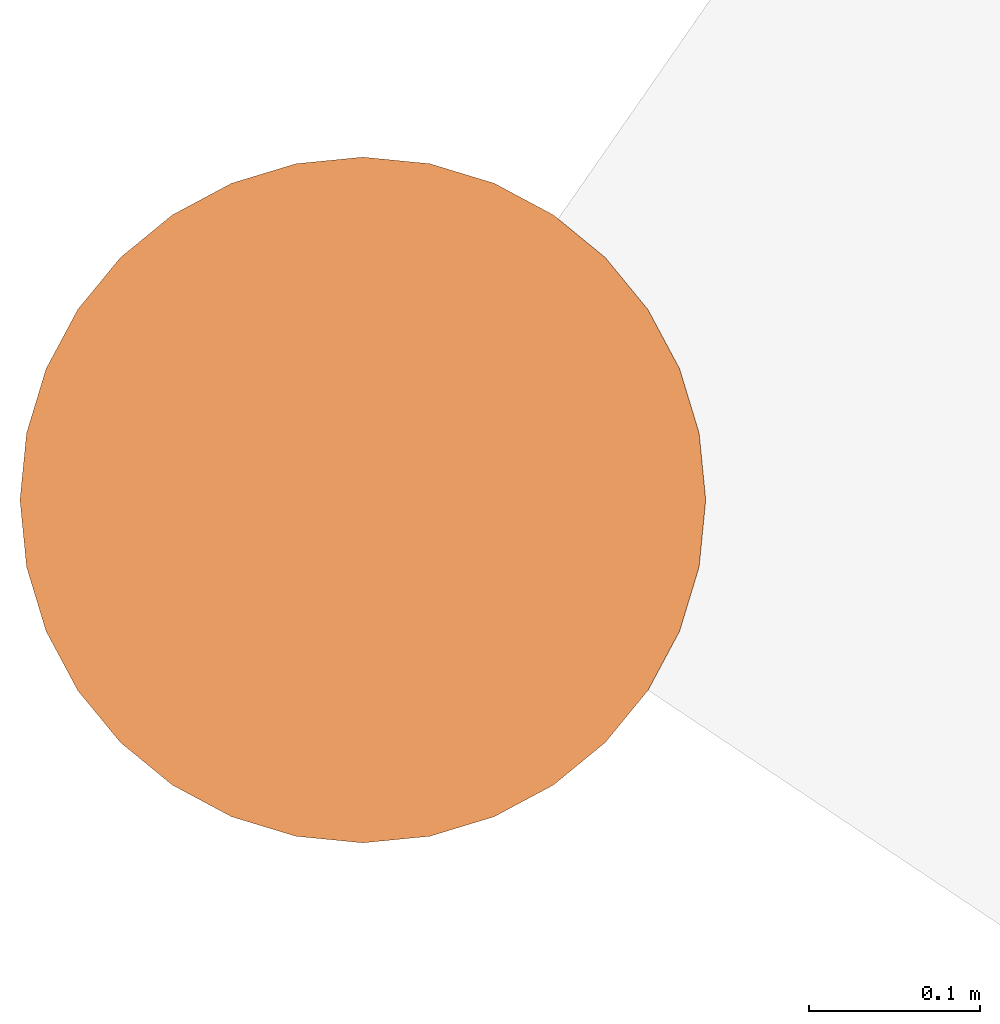
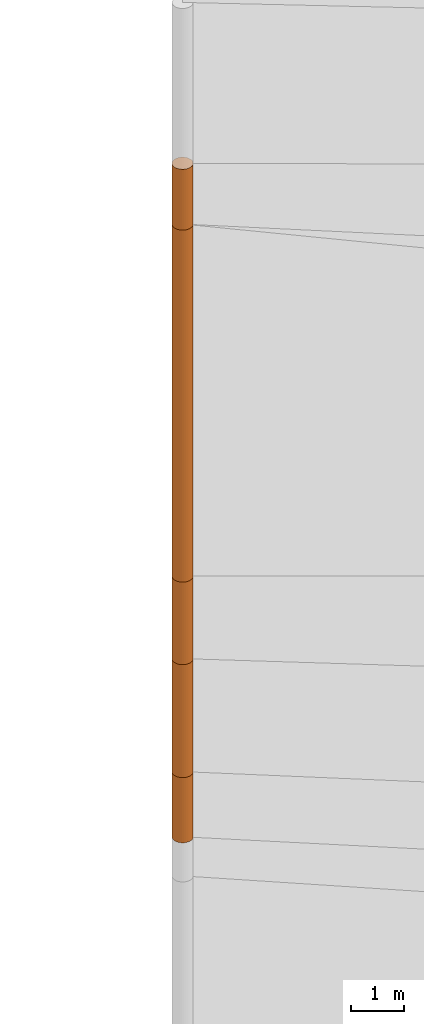
# One storey, part 4 of 24: 5 geographic elements.
"""IFC4 building model written with IfcOpenShell, lengths in metres."""

from ifc_helpers import new_model, entity, si_unit, converted_unit, frame, origin_with_axes, origin_2d_with_axis, place, context, subcontext, project, spatial, polygons, element, save


model = new_model("IFC4")

# Units and contexts
model_context = context("Model", 3, precision=1e-05, world=origin_with_axes())
plan_context = context("Plan", 2, precision=1e-05, world=origin_2d_with_axis())
body_context = subcontext(model_context, "Body", "Model", "MODEL_VIEW")
ifc_project = project(units=[converted_unit("PLANEANGLEUNIT", "degree", entity("IfcReal", 0.0174532925199433), si_unit("PLANEANGLEUNIT", "RADIAN"), dimensions=[0, 0, 0, 0, 0, 0, 0]), si_unit("AREAUNIT", "SQUARE_METRE"), si_unit("VOLUMEUNIT", "CUBIC_METRE"), si_unit("LENGTHUNIT", "METRE")], contexts=[model_context, plan_context])

# Site, building, storey
site_placement = place(None, origin_with_axes())
site = spatial("IfcSite", under=ifc_project, at=site_placement)
building_placement = place(site_placement, origin_with_axes())
building = spatial("IfcBuilding", under=site, at=building_placement, Name="Building")
storey_placement = place(building_placement, origin_with_axes())
storey = spatial("IfcBuildingStorey", under=building, at=storey_placement, Name="Storey")

# Geographic elements
geographic_element_1_placement = place(storey_placement, frame((-24.2999992370605, 16.2000007629395, -3.35000014305115), z_axis=(0.0, 0.0, 1.0), x_axis=(1.0, 0.0, 0.0)))
element("IfcGeographicElement", 1, at=geographic_element_1_placement, inside=storey, PredefinedType="NOTDEFINED", context=body_context, shape_type="Tessellation", body=[
    polygons([(0.0, 0.0, -0.749999940395355), (0.0390180610120296, 0.196157038211823, -0.749999940395355), (0.0, 0.199999988079071, -0.749999940395355), (0.0, 0.0, 0.749999940395355), (0.0, 0.199999988079071, 0.749999940395355), (0.0390180610120296, 0.196157038211823, 0.749999940395355), (0.0765366926789284, 0.18477588891983, -0.749999940395355), (0.0765366926789284, 0.18477588891983, 0.749999940395355), (0.111114047467709, 0.166293919086456, -0.749999940395355), (0.111114047467709, 0.166293919086456, 0.749999940395355), (0.141421362757683, 0.141421362757683, -0.749999940395355), (0.141421362757683, 0.141421362757683, 0.749999940395355), (0.166293919086456, 0.111114047467709, -0.749999940395355), (0.166293919086456, 0.111114047467709, 0.749999940395355), (0.18477588891983, 0.0765366926789284, -0.749999940395355), (0.18477588891983, 0.0765366926789284, 0.749999940395355), (0.196157038211823, 0.0390180610120296, -0.749999940395355), (0.196157038211823, 0.0390180610120296, 0.749999940395355), (0.199999988079071, 0.0, -0.749999940395355), (0.199999988079071, 0.0, 0.749999940395355), (0.196157038211823, -0.0390180610120296, -0.749999940395355), (0.196157038211823, -0.0390180610120296, 0.749999940395355), (0.18477588891983, -0.0765366926789284, -0.749999940395355), (0.18477588891983, -0.0765366926789284, 0.749999940395355), (0.166293919086456, -0.111114047467709, -0.749999940395355), (0.166293919086456, -0.111114047467709, 0.749999940395355), (0.141421362757683, -0.141421362757683, -0.749999940395355), (0.141421362757683, -0.141421362757683, 0.749999940395355), (0.111114047467709, -0.166293919086456, -0.749999940395355), (0.111114047467709, -0.166293919086456, 0.749999940395355), (0.0765366926789284, -0.18477588891983, -0.749999940395355), (0.0765366926789284, -0.18477588891983, 0.749999940395355), (0.0390180610120296, -0.196157038211823, -0.749999940395355), (0.0390180610120296, -0.196157038211823, 0.749999940395355), (0.0, -0.199999988079071, -0.749999940395355), (0.0, -0.199999988079071, 0.749999940395355), (-0.0390180610120296, -0.196157038211823, -0.749999940395355), (-0.0390180610120296, -0.196157038211823, 0.749999940395355), (-0.0765366926789284, -0.18477588891983, -0.749999940395355), (-0.0765366926789284, -0.18477588891983, 0.749999940395355), (-0.111114047467709, -0.166293919086456, -0.749999940395355), (-0.111114047467709, -0.166293919086456, 0.749999940395355), (-0.141421362757683, -0.141421362757683, -0.749999940395355), (-0.141421362757683, -0.141421362757683, 0.749999940395355), (-0.166293919086456, -0.111114047467709, -0.749999940395355), (-0.166293919086456, -0.111114047467709, 0.749999940395355), (-0.18477588891983, -0.0765366926789284, -0.749999940395355), (-0.18477588891983, -0.0765366926789284, 0.749999940395355), (-0.196157038211823, -0.0390180610120296, -0.749999940395355), (-0.196157038211823, -0.0390180610120296, 0.749999940395355), (-0.199999988079071, 0.0, -0.749999940395355), (-0.199999988079071, 0.0, 0.749999940395355), (-0.196157038211823, 0.0390180610120296, -0.749999940395355), (-0.196157038211823, 0.0390180610120296, 0.749999940395355), (-0.18477588891983, 0.0765366926789284, -0.749999940395355), (-0.18477588891983, 0.0765366926789284, 0.749999940395355), (-0.166293919086456, 0.111114047467709, -0.749999940395355), (-0.166293919086456, 0.111114047467709, 0.749999940395355), (-0.141421362757683, 0.141421362757683, -0.749999940395355), (-0.141421362757683, 0.141421362757683, 0.749999940395355), (-0.111114047467709, 0.166293919086456, -0.749999940395355), (-0.111114047467709, 0.166293919086456, 0.749999940395355), (-0.0765366926789284, 0.18477588891983, -0.749999940395355), (-0.0765366926789284, 0.18477588891983, 0.749999940395355), (-0.0390180610120296, 0.196157038211823, -0.749999940395355), (-0.0390180610120296, 0.196157038211823, 0.749999940395355)], [[[3, 2, 1]], [[6, 5, 4]], [[28, 30, 29, 27]], [[2, 7, 1]], [[8, 6, 4]], [[36, 38, 37, 35]], [[7, 9, 1]], [[10, 8, 4]], [[56, 58, 57, 55]], [[9, 11, 1]], [[12, 10, 4]], [[58, 60, 59, 57]], [[11, 13, 1]], [[12, 4, 14]], [[54, 56, 55, 53]], [[1, 13, 15]], [[4, 16, 14]], [[10, 12, 11, 9]], [[1, 15, 17]], [[4, 18, 16]], [[60, 62, 61, 59]], [[1, 17, 19]], [[4, 20, 18]], [[16, 18, 17, 15]], [[1, 19, 21]], [[20, 4, 22]], [[18, 20, 19, 17]], [[1, 21, 23]], [[4, 24, 22]], [[20, 22, 21, 19]], [[1, 23, 25]], [[24, 4, 26]], [[22, 24, 23, 21]], [[1, 25, 27]], [[26, 4, 28]], [[24, 26, 25, 23]], [[1, 27, 29]], [[28, 4, 30]], [[62, 64, 63, 61]], [[1, 29, 31]], [[4, 32, 30]], [[64, 66, 65, 63]], [[1, 31, 33]], [[4, 34, 32]], [[30, 32, 31, 29]], [[1, 33, 35]], [[4, 36, 34]], [[8, 10, 9, 7]], [[1, 35, 37]], [[4, 38, 36]], [[32, 34, 33, 31]], [[1, 37, 39]], [[4, 40, 38]], [[6, 8, 7, 2]], [[1, 39, 41]], [[4, 42, 40]], [[38, 40, 39, 37]], [[43, 1, 41]], [[4, 44, 42]], [[40, 42, 41, 39]], [[45, 1, 43]], [[4, 46, 44]], [[42, 44, 43, 41]], [[47, 1, 45]], [[48, 46, 4]], [[44, 46, 45, 43]], [[47, 49, 1]], [[50, 48, 4]], [[46, 48, 47, 45]], [[51, 1, 49]], [[52, 50, 4]], [[48, 50, 49, 47]], [[51, 53, 1]], [[4, 54, 52]], [[66, 5, 3, 65]], [[53, 55, 1]], [[56, 54, 4]], [[52, 54, 53, 51]], [[55, 57, 1]], [[4, 58, 56]], [[59, 1, 57]], [[60, 58, 4]], [[34, 36, 35, 33]], [[59, 61, 1]], [[62, 60, 4]], [[14, 16, 15, 13]], [[61, 63, 1]], [[64, 62, 4]], [[26, 28, 27, 25]], [[63, 65, 1]], [[66, 64, 4]], [[5, 6, 2, 3]], [[65, 3, 1]], [[5, 66, 4]], [[50, 52, 51, 49]], [[12, 14, 13, 11]]]),
])
geographic_element_2_placement = place(storey_placement, frame((-24.2999992370605, 16.2000007629395, -1.30000019073486), z_axis=(0.0, 0.0, 1.0), x_axis=(1.0, 0.0, 0.0)))
element("IfcGeographicElement", 2, at=geographic_element_2_placement, inside=storey, PredefinedType="NOTDEFINED", context=body_context, shape_type="Tessellation", body=[
    polygons([(0.0, 0.0, -1.29999983310699), (0.0390180610120296, 0.196157038211823, -1.29999983310699), (0.0, 0.199999988079071, -1.29999983310699), (0.0, 0.0, 1.29999983310699), (0.0, 0.199999988079071, 1.29999983310699), (0.0390180610120296, 0.196157038211823, 1.29999983310699), (0.0765366926789284, 0.18477588891983, -1.29999983310699), (0.0765366926789284, 0.18477588891983, 1.29999983310699), (0.111114047467709, 0.166293919086456, -1.29999983310699), (0.111114047467709, 0.166293919086456, 1.29999983310699), (0.141421362757683, 0.141421362757683, -1.29999983310699), (0.141421362757683, 0.141421362757683, 1.29999983310699), (0.166293919086456, 0.111114047467709, -1.29999983310699), (0.166293919086456, 0.111114047467709, 1.29999983310699), (0.18477588891983, 0.0765366926789284, -1.29999983310699), (0.18477588891983, 0.0765366926789284, 1.29999983310699), (0.196157038211823, 0.0390180610120296, -1.29999983310699), (0.196157038211823, 0.0390180610120296, 1.29999983310699), (0.199999988079071, 0.0, -1.29999983310699), (0.199999988079071, 0.0, 1.29999983310699), (0.196157038211823, -0.0390180610120296, -1.29999983310699), (0.196157038211823, -0.0390180610120296, 1.29999983310699), (0.18477588891983, -0.0765366926789284, -1.29999983310699), (0.18477588891983, -0.0765366926789284, 1.29999983310699), (0.166293919086456, -0.111114047467709, -1.29999983310699), (0.166293919086456, -0.111114047467709, 1.29999983310699), (0.141421362757683, -0.141421362757683, -1.29999983310699), (0.141421362757683, -0.141421362757683, 1.29999983310699), (0.111114047467709, -0.166293919086456, -1.29999983310699), (0.111114047467709, -0.166293919086456, 1.29999983310699), (0.0765366926789284, -0.18477588891983, -1.29999983310699), (0.0765366926789284, -0.18477588891983, 1.29999983310699), (0.0390180610120296, -0.196157038211823, -1.29999983310699), (0.0390180610120296, -0.196157038211823, 1.29999983310699), (0.0, -0.199999988079071, -1.29999983310699), (0.0, -0.199999988079071, 1.29999983310699), (-0.0390180610120296, -0.196157038211823, -1.29999983310699), (-0.0390180610120296, -0.196157038211823, 1.29999983310699), (-0.0765366926789284, -0.18477588891983, -1.29999983310699), (-0.0765366926789284, -0.18477588891983, 1.29999983310699), (-0.111114047467709, -0.166293919086456, -1.29999983310699), (-0.111114047467709, -0.166293919086456, 1.29999983310699), (-0.141421362757683, -0.141421362757683, -1.29999983310699), (-0.141421362757683, -0.141421362757683, 1.29999983310699), (-0.166293919086456, -0.111114047467709, -1.29999983310699), (-0.166293919086456, -0.111114047467709, 1.29999983310699), (-0.18477588891983, -0.0765366926789284, -1.29999983310699), (-0.18477588891983, -0.0765366926789284, 1.29999983310699), (-0.196157038211823, -0.0390180610120296, -1.29999983310699), (-0.196157038211823, -0.0390180610120296, 1.29999983310699), (-0.199999988079071, 0.0, -1.29999983310699), (-0.199999988079071, 0.0, 1.29999983310699), (-0.196157038211823, 0.0390180610120296, -1.29999983310699), (-0.196157038211823, 0.0390180610120296, 1.29999983310699), (-0.18477588891983, 0.0765366926789284, -1.29999983310699), (-0.18477588891983, 0.0765366926789284, 1.29999983310699), (-0.166293919086456, 0.111114047467709, -1.29999983310699), (-0.166293919086456, 0.111114047467709, 1.29999983310699), (-0.141421362757683, 0.141421362757683, -1.29999983310699), (-0.141421362757683, 0.141421362757683, 1.29999983310699), (-0.111114047467709, 0.166293919086456, -1.29999983310699), (-0.111114047467709, 0.166293919086456, 1.29999983310699), (-0.0765366926789284, 0.18477588891983, -1.29999983310699), (-0.0765366926789284, 0.18477588891983, 1.29999983310699), (-0.0390180610120296, 0.196157038211823, -1.29999983310699), (-0.0390180610120296, 0.196157038211823, 1.29999983310699)], [[[3, 2, 1]], [[6, 5, 4]], [[32, 34, 33, 31]], [[2, 7, 1]], [[8, 6, 4]], [[64, 66, 65, 63]], [[7, 9, 1]], [[10, 8, 4]], [[9, 11, 1]], [[12, 10, 4]], [[40, 42, 41, 39]], [[1, 11, 13]], [[12, 4, 14]], [[10, 12, 11, 9]], [[1, 13, 15]], [[4, 16, 14]], [[12, 14, 13, 11]], [[1, 15, 17]], [[4, 18, 16]], [[18, 20, 19, 17]], [[1, 17, 19]], [[18, 4, 20]], [[20, 22, 21, 19]], [[1, 19, 21]], [[20, 4, 22]], [[22, 24, 23, 21]], [[1, 21, 23]], [[4, 24, 22]], [[54, 56, 55, 53]], [[1, 23, 25]], [[4, 26, 24]], [[56, 58, 57, 55]], [[27, 1, 25]], [[4, 28, 26]], [[24, 26, 25, 23]], [[1, 27, 29]], [[28, 4, 30]], [[26, 28, 27, 25]], [[1, 29, 31]], [[4, 32, 30]], [[46, 48, 47, 45]], [[1, 31, 33]], [[4, 34, 32]], [[36, 38, 37, 35]], [[1, 33, 35]], [[4, 36, 34]], [[42, 44, 43, 41]], [[1, 35, 37]], [[4, 38, 36]], [[38, 40, 39, 37]], [[1, 37, 39]], [[4, 40, 38]], [[34, 36, 35, 33]], [[1, 39, 41]], [[4, 42, 40]], [[8, 10, 9, 7]], [[43, 1, 41]], [[4, 44, 42]], [[44, 46, 45, 43]], [[43, 45, 1]], [[46, 44, 4]], [[30, 32, 31, 29]], [[45, 47, 1]], [[48, 46, 4]], [[28, 30, 29, 27]], [[47, 49, 1]], [[50, 48, 4]], [[5, 6, 2, 3]], [[51, 1, 49]], [[4, 52, 50]], [[48, 50, 49, 47]], [[53, 1, 51]], [[4, 54, 52]], [[50, 52, 51, 49]], [[53, 55, 1]], [[56, 54, 4]], [[52, 54, 53, 51]], [[55, 57, 1]], [[58, 56, 4]], [[58, 60, 59, 57]], [[57, 59, 1]], [[60, 58, 4]], [[60, 62, 61, 59]], [[59, 61, 1]], [[62, 60, 4]], [[62, 64, 63, 61]], [[61, 63, 1]], [[64, 62, 4]], [[14, 16, 15, 13]], [[63, 65, 1]], [[66, 64, 4]], [[16, 18, 17, 15]], [[65, 3, 1]], [[5, 66, 4]], [[6, 8, 7, 2]], [[66, 5, 3, 65]]]),
])
geographic_element_3_placement = place(storey_placement, frame((-24.2999992370605, 16.2000007629395, 0.949999809265137), z_axis=(0.0, 0.0, 1.0), x_axis=(1.0, 0.0, 0.0)))
element("IfcGeographicElement", 3, at=geographic_element_3_placement, inside=storey, PredefinedType="NOTDEFINED", context=body_context, shape_type="Tessellation", body=[
    polygons([(0.0, 0.0, -0.949999928474426), (0.0390180610120296, 0.196157038211823, -0.949999928474426), (0.0, 0.199999988079071, -0.949999928474426), (0.0, 0.0, 0.949999928474426), (0.0, 0.199999988079071, 0.949999928474426), (0.0390180610120296, 0.196157038211823, 0.949999928474426), (0.0765366926789284, 0.18477588891983, -0.949999928474426), (0.0765366926789284, 0.18477588891983, 0.949999928474426), (0.111114047467709, 0.166293919086456, -0.949999928474426), (0.111114047467709, 0.166293919086456, 0.949999928474426), (0.141421362757683, 0.141421362757683, -0.949999928474426), (0.141421362757683, 0.141421362757683, 0.949999928474426), (0.166293919086456, 0.111114047467709, -0.949999928474426), (0.166293919086456, 0.111114047467709, 0.949999928474426), (0.18477588891983, 0.0765366926789284, -0.949999928474426), (0.18477588891983, 0.0765366926789284, 0.949999928474426), (0.196157038211823, 0.0390180610120296, -0.949999928474426), (0.196157038211823, 0.0390180610120296, 0.949999928474426), (0.199999988079071, 0.0, -0.949999928474426), (0.199999988079071, 0.0, 0.949999928474426), (0.196157038211823, -0.0390180610120296, -0.949999928474426), (0.196157038211823, -0.0390180610120296, 0.949999928474426), (0.18477588891983, -0.0765366926789284, -0.949999928474426), (0.18477588891983, -0.0765366926789284, 0.949999928474426), (0.166293919086456, -0.111114047467709, -0.949999928474426), (0.166293919086456, -0.111114047467709, 0.949999928474426), (0.141421362757683, -0.141421362757683, -0.949999928474426), (0.141421362757683, -0.141421362757683, 0.949999928474426), (0.111114047467709, -0.166293919086456, -0.949999928474426), (0.111114047467709, -0.166293919086456, 0.949999928474426), (0.0765366926789284, -0.18477588891983, -0.949999928474426), (0.0765366926789284, -0.18477588891983, 0.949999928474426), (0.0390180610120296, -0.196157038211823, -0.949999928474426), (0.0390180610120296, -0.196157038211823, 0.949999928474426), (0.0, -0.199999988079071, -0.949999928474426), (0.0, -0.199999988079071, 0.949999928474426), (-0.0390180610120296, -0.196157038211823, -0.949999928474426), (-0.0390180610120296, -0.196157038211823, 0.949999928474426), (-0.0765366926789284, -0.18477588891983, -0.949999928474426), (-0.0765366926789284, -0.18477588891983, 0.949999928474426), (-0.111114047467709, -0.166293919086456, -0.949999928474426), (-0.111114047467709, -0.166293919086456, 0.949999928474426), (-0.141421362757683, -0.141421362757683, -0.949999928474426), (-0.141421362757683, -0.141421362757683, 0.949999928474426), (-0.166293919086456, -0.111114047467709, -0.949999928474426), (-0.166293919086456, -0.111114047467709, 0.949999928474426), (-0.18477588891983, -0.0765366926789284, -0.949999928474426), (-0.18477588891983, -0.0765366926789284, 0.949999928474426), (-0.196157038211823, -0.0390180610120296, -0.949999928474426), (-0.196157038211823, -0.0390180610120296, 0.949999928474426), (-0.199999988079071, 0.0, -0.949999928474426), (-0.199999988079071, 0.0, 0.949999928474426), (-0.196157038211823, 0.0390180610120296, -0.949999928474426), (-0.196157038211823, 0.0390180610120296, 0.949999928474426), (-0.18477588891983, 0.0765366926789284, -0.949999928474426), (-0.18477588891983, 0.0765366926789284, 0.949999928474426), (-0.166293919086456, 0.111114047467709, -0.949999928474426), (-0.166293919086456, 0.111114047467709, 0.949999928474426), (-0.141421362757683, 0.141421362757683, -0.949999928474426), (-0.141421362757683, 0.141421362757683, 0.949999928474426), (-0.111114047467709, 0.166293919086456, -0.949999928474426), (-0.111114047467709, 0.166293919086456, 0.949999928474426), (-0.0765366926789284, 0.18477588891983, -0.949999928474426), (-0.0765366926789284, 0.18477588891983, 0.949999928474426), (-0.0390180610120296, 0.196157038211823, -0.949999928474426), (-0.0390180610120296, 0.196157038211823, 0.949999928474426)], [[[3, 2, 1]], [[6, 5, 4]], [[32, 34, 33, 31]], [[2, 7, 1]], [[8, 6, 4]], [[64, 66, 65, 63]], [[7, 9, 1]], [[10, 8, 4]], [[9, 11, 1]], [[12, 10, 4]], [[40, 42, 41, 39]], [[1, 11, 13]], [[12, 4, 14]], [[10, 12, 11, 9]], [[1, 13, 15]], [[4, 16, 14]], [[12, 14, 13, 11]], [[1, 15, 17]], [[16, 4, 18]], [[18, 20, 19, 17]], [[1, 17, 19]], [[4, 20, 18]], [[20, 22, 21, 19]], [[1, 19, 21]], [[4, 22, 20]], [[22, 24, 23, 21]], [[1, 21, 23]], [[4, 24, 22]], [[54, 56, 55, 53]], [[1, 23, 25]], [[4, 26, 24]], [[56, 58, 57, 55]], [[27, 1, 25]], [[4, 28, 26]], [[24, 26, 25, 23]], [[1, 27, 29]], [[28, 4, 30]], [[26, 28, 27, 25]], [[1, 29, 31]], [[4, 32, 30]], [[46, 48, 47, 45]], [[1, 31, 33]], [[4, 34, 32]], [[36, 38, 37, 35]], [[1, 33, 35]], [[4, 36, 34]], [[42, 44, 43, 41]], [[1, 35, 37]], [[4, 38, 36]], [[38, 40, 39, 37]], [[1, 37, 39]], [[4, 40, 38]], [[34, 36, 35, 33]], [[1, 39, 41]], [[4, 42, 40]], [[8, 10, 9, 7]], [[43, 1, 41]], [[4, 44, 42]], [[44, 46, 45, 43]], [[43, 45, 1]], [[46, 44, 4]], [[30, 32, 31, 29]], [[45, 47, 1]], [[48, 46, 4]], [[28, 30, 29, 27]], [[47, 49, 1]], [[4, 50, 48]], [[5, 6, 2, 3]], [[49, 51, 1]], [[52, 50, 4]], [[48, 50, 49, 47]], [[51, 53, 1]], [[54, 52, 4]], [[50, 52, 51, 49]], [[55, 1, 53]], [[56, 54, 4]], [[52, 54, 53, 51]], [[55, 57, 1]], [[58, 56, 4]], [[58, 60, 59, 57]], [[57, 59, 1]], [[60, 58, 4]], [[60, 62, 61, 59]], [[59, 61, 1]], [[62, 60, 4]], [[62, 64, 63, 61]], [[61, 63, 1]], [[64, 62, 4]], [[14, 16, 15, 13]], [[63, 65, 1]], [[66, 64, 4]], [[16, 18, 17, 15]], [[65, 3, 1]], [[5, 66, 4]], [[6, 8, 7, 2]], [[66, 5, 3, 65]]]),
])
geographic_element_4_placement = place(storey_placement, frame((-24.2999992370605, 16.2000007629395, 5.94999980926514), z_axis=(0.0, 0.0, 1.0), x_axis=(1.0, 0.0, 0.0)))
element("IfcGeographicElement", 4, at=geographic_element_4_placement, inside=storey, PredefinedType="NOTDEFINED", context=body_context, shape_type="Tessellation", body=[
    polygons([(0.0, 0.0, -4.05000019073486), (0.0390180610120296, 0.196157038211823, -4.05000019073486), (0.0, 0.199999988079071, -4.05000019073486), (0.0, 0.0, 4.05000019073486), (0.0, 0.199999988079071, 4.05000019073486), (0.0390180610120296, 0.196157038211823, 4.05000019073486), (0.0765366926789284, 0.18477588891983, -4.05000019073486), (0.0765366926789284, 0.18477588891983, 4.05000019073486), (0.111114047467709, 0.166293919086456, -4.05000019073486), (0.111114047467709, 0.166293919086456, 4.05000019073486), (0.141421362757683, 0.141421362757683, -4.05000019073486), (0.141421362757683, 0.141421362757683, 4.05000019073486), (0.166293919086456, 0.111114047467709, -4.05000019073486), (0.166293919086456, 0.111114047467709, 4.05000019073486), (0.18477588891983, 0.0765366926789284, -4.05000019073486), (0.18477588891983, 0.0765366926789284, 4.05000019073486), (0.196157038211823, 0.0390180610120296, -4.05000019073486), (0.196157038211823, 0.0390180610120296, 4.05000019073486), (0.199999988079071, 0.0, -4.05000019073486), (0.199999988079071, 0.0, 4.05000019073486), (0.196157038211823, -0.0390180610120296, -4.05000019073486), (0.196157038211823, -0.0390180610120296, 4.05000019073486), (0.18477588891983, -0.0765366926789284, -4.05000019073486), (0.18477588891983, -0.0765366926789284, 4.05000019073486), (0.166293919086456, -0.111114047467709, -4.05000019073486), (0.166293919086456, -0.111114047467709, 4.05000019073486), (0.141421362757683, -0.141421362757683, -4.05000019073486), (0.141421362757683, -0.141421362757683, 4.05000019073486), (0.111114047467709, -0.166293919086456, -4.05000019073486), (0.111114047467709, -0.166293919086456, 4.05000019073486), (0.0765366926789284, -0.18477588891983, -4.05000019073486), (0.0765366926789284, -0.18477588891983, 4.05000019073486), (0.0390180610120296, -0.196157038211823, -4.05000019073486), (0.0390180610120296, -0.196157038211823, 4.05000019073486), (0.0, -0.199999988079071, -4.05000019073486), (0.0, -0.199999988079071, 4.05000019073486), (-0.0390180610120296, -0.196157038211823, -4.05000019073486), (-0.0390180610120296, -0.196157038211823, 4.05000019073486), (-0.0765366926789284, -0.18477588891983, -4.05000019073486), (-0.0765366926789284, -0.18477588891983, 4.05000019073486), (-0.111114047467709, -0.166293919086456, -4.05000019073486), (-0.111114047467709, -0.166293919086456, 4.05000019073486), (-0.141421362757683, -0.141421362757683, -4.05000019073486), (-0.141421362757683, -0.141421362757683, 4.05000019073486), (-0.166293919086456, -0.111114047467709, -4.05000019073486), (-0.166293919086456, -0.111114047467709, 4.05000019073486), (-0.18477588891983, -0.0765366926789284, -4.05000019073486), (-0.18477588891983, -0.0765366926789284, 4.05000019073486), (-0.196157038211823, -0.0390180610120296, -4.05000019073486), (-0.196157038211823, -0.0390180610120296, 4.05000019073486), (-0.199999988079071, 0.0, -4.05000019073486), (-0.199999988079071, 0.0, 4.05000019073486), (-0.196157038211823, 0.0390180610120296, -4.05000019073486), (-0.196157038211823, 0.0390180610120296, 4.05000019073486), (-0.18477588891983, 0.0765366926789284, -4.05000019073486), (-0.18477588891983, 0.0765366926789284, 4.05000019073486), (-0.166293919086456, 0.111114047467709, -4.05000019073486), (-0.166293919086456, 0.111114047467709, 4.05000019073486), (-0.141421362757683, 0.141421362757683, -4.05000019073486), (-0.141421362757683, 0.141421362757683, 4.05000019073486), (-0.111114047467709, 0.166293919086456, -4.05000019073486), (-0.111114047467709, 0.166293919086456, 4.05000019073486), (-0.0765366926789284, 0.18477588891983, -4.05000019073486), (-0.0765366926789284, 0.18477588891983, 4.05000019073486), (-0.0390180610120296, 0.196157038211823, -4.05000019073486), (-0.0390180610120296, 0.196157038211823, 4.05000019073486)], [[[3, 2, 1]], [[6, 5, 4]], [[28, 30, 29, 27]], [[2, 7, 1]], [[8, 6, 4]], [[64, 66, 65, 63]], [[7, 9, 1]], [[10, 8, 4]], [[9, 11, 1]], [[12, 10, 4]], [[6, 8, 7, 2]], [[1, 11, 13]], [[12, 4, 14]], [[66, 5, 3, 65]], [[1, 13, 15]], [[14, 4, 16]], [[12, 14, 13, 11]], [[1, 15, 17]], [[16, 4, 18]], [[14, 16, 15, 13]], [[1, 17, 19]], [[4, 20, 18]], [[16, 18, 17, 15]], [[1, 19, 21]], [[20, 4, 22]], [[18, 20, 19, 17]], [[1, 21, 23]], [[22, 4, 24]], [[20, 22, 21, 19]], [[1, 23, 25]], [[24, 4, 26]], [[22, 24, 23, 21]], [[1, 25, 27]], [[4, 28, 26]], [[24, 26, 25, 23]], [[1, 27, 29]], [[28, 4, 30]], [[26, 28, 27, 25]], [[1, 29, 31]], [[4, 32, 30]], [[5, 6, 2, 3]], [[1, 31, 33]], [[4, 34, 32]], [[30, 32, 31, 29]], [[1, 33, 35]], [[4, 36, 34]], [[8, 10, 9, 7]], [[1, 35, 37]], [[4, 38, 36]], [[32, 34, 33, 31]], [[1, 37, 39]], [[4, 40, 38]], [[36, 38, 37, 35]], [[1, 39, 41]], [[4, 42, 40]], [[38, 40, 39, 37]], [[43, 1, 41]], [[4, 44, 42]], [[40, 42, 41, 39]], [[43, 45, 1]], [[4, 46, 44]], [[42, 44, 43, 41]], [[47, 1, 45]], [[4, 48, 46]], [[44, 46, 45, 43]], [[49, 1, 47]], [[4, 50, 48]], [[46, 48, 47, 45]], [[51, 1, 49]], [[52, 50, 4]], [[48, 50, 49, 47]], [[51, 53, 1]], [[4, 54, 52]], [[50, 52, 51, 49]], [[55, 1, 53]], [[4, 56, 54]], [[52, 54, 53, 51]], [[57, 1, 55]], [[4, 58, 56]], [[54, 56, 55, 53]], [[59, 1, 57]], [[60, 58, 4]], [[56, 58, 57, 55]], [[59, 61, 1]], [[62, 60, 4]], [[58, 60, 59, 57]], [[61, 63, 1]], [[64, 62, 4]], [[60, 62, 61, 59]], [[63, 65, 1]], [[66, 64, 4]], [[62, 64, 63, 61]], [[65, 3, 1]], [[5, 66, 4]], [[34, 36, 35, 33]], [[10, 12, 11, 9]]]),
])
geographic_element_5_placement = place(storey_placement, frame((-24.2999992370605, 16.2000007629395, 10.6999998092651), z_axis=(0.0, 0.0, 1.0), x_axis=(1.0, 0.0, 0.0)))
element("IfcGeographicElement", 5, at=geographic_element_5_placement, inside=storey, PredefinedType="NOTDEFINED", context=body_context, shape_type="Tessellation", body=[
    polygons([(0.0, 0.0, -0.699999928474426), (0.0390180610120296, 0.196157038211823, -0.699999928474426), (0.0, 0.199999988079071, -0.699999928474426), (0.0, 0.0, 0.699999928474426), (0.0, 0.199999988079071, 0.699999928474426), (0.0390180610120296, 0.196157038211823, 0.699999928474426), (0.0765366926789284, 0.18477588891983, -0.699999928474426), (0.0765366926789284, 0.18477588891983, 0.699999928474426), (0.111114047467709, 0.166293919086456, -0.699999928474426), (0.111114047467709, 0.166293919086456, 0.699999928474426), (0.141421362757683, 0.141421362757683, -0.699999928474426), (0.141421362757683, 0.141421362757683, 0.699999928474426), (0.166293919086456, 0.111114047467709, -0.699999928474426), (0.166293919086456, 0.111114047467709, 0.699999928474426), (0.18477588891983, 0.0765366926789284, -0.699999928474426), (0.18477588891983, 0.0765366926789284, 0.699999928474426), (0.196157038211823, 0.0390180610120296, -0.699999928474426), (0.196157038211823, 0.0390180610120296, 0.699999928474426), (0.199999988079071, 0.0, -0.699999928474426), (0.199999988079071, 0.0, 0.699999928474426), (0.196157038211823, -0.0390180610120296, -0.699999928474426), (0.196157038211823, -0.0390180610120296, 0.699999928474426), (0.18477588891983, -0.0765366926789284, -0.699999928474426), (0.18477588891983, -0.0765366926789284, 0.699999928474426), (0.166293919086456, -0.111114047467709, -0.699999928474426), (0.166293919086456, -0.111114047467709, 0.699999928474426), (0.141421362757683, -0.141421362757683, -0.699999928474426), (0.141421362757683, -0.141421362757683, 0.699999928474426), (0.111114047467709, -0.166293919086456, -0.699999928474426), (0.111114047467709, -0.166293919086456, 0.699999928474426), (0.0765366926789284, -0.18477588891983, -0.699999928474426), (0.0765366926789284, -0.18477588891983, 0.699999928474426), (0.0390180610120296, -0.196157038211823, -0.699999928474426), (0.0390180610120296, -0.196157038211823, 0.699999928474426), (0.0, -0.199999988079071, -0.699999928474426), (0.0, -0.199999988079071, 0.699999928474426), (-0.0390180610120296, -0.196157038211823, -0.699999928474426), (-0.0390180610120296, -0.196157038211823, 0.699999928474426), (-0.0765366926789284, -0.18477588891983, -0.699999928474426), (-0.0765366926789284, -0.18477588891983, 0.699999928474426), (-0.111114047467709, -0.166293919086456, -0.699999928474426), (-0.111114047467709, -0.166293919086456, 0.699999928474426), (-0.141421362757683, -0.141421362757683, -0.699999928474426), (-0.141421362757683, -0.141421362757683, 0.699999928474426), (-0.166293919086456, -0.111114047467709, -0.699999928474426), (-0.166293919086456, -0.111114047467709, 0.699999928474426), (-0.18477588891983, -0.0765366926789284, -0.699999928474426), (-0.18477588891983, -0.0765366926789284, 0.699999928474426), (-0.196157038211823, -0.0390180610120296, -0.699999928474426), (-0.196157038211823, -0.0390180610120296, 0.699999928474426), (-0.199999988079071, 0.0, -0.699999928474426), (-0.199999988079071, 0.0, 0.699999928474426), (-0.196157038211823, 0.0390180610120296, -0.699999928474426), (-0.196157038211823, 0.0390180610120296, 0.699999928474426), (-0.18477588891983, 0.0765366926789284, -0.699999928474426), (-0.18477588891983, 0.0765366926789284, 0.699999928474426), (-0.166293919086456, 0.111114047467709, -0.699999928474426), (-0.166293919086456, 0.111114047467709, 0.699999928474426), (-0.141421362757683, 0.141421362757683, -0.699999928474426), (-0.141421362757683, 0.141421362757683, 0.699999928474426), (-0.111114047467709, 0.166293919086456, -0.699999928474426), (-0.111114047467709, 0.166293919086456, 0.699999928474426), (-0.0765366926789284, 0.18477588891983, -0.699999928474426), (-0.0765366926789284, 0.18477588891983, 0.699999928474426), (-0.0390180610120296, 0.196157038211823, -0.699999928474426), (-0.0390180610120296, 0.196157038211823, 0.699999928474426)], [[[3, 2, 1]], [[6, 5, 4]], [[28, 30, 29, 27]], [[2, 7, 1]], [[8, 6, 4]], [[36, 38, 37, 35]], [[7, 9, 1]], [[10, 8, 4]], [[56, 58, 57, 55]], [[9, 11, 1]], [[12, 10, 4]], [[58, 60, 59, 57]], [[11, 13, 1]], [[12, 4, 14]], [[54, 56, 55, 53]], [[1, 13, 15]], [[4, 16, 14]], [[10, 12, 11, 9]], [[1, 15, 17]], [[4, 18, 16]], [[60, 62, 61, 59]], [[1, 17, 19]], [[4, 20, 18]], [[16, 18, 17, 15]], [[1, 19, 21]], [[4, 22, 20]], [[18, 20, 19, 17]], [[1, 21, 23]], [[4, 24, 22]], [[20, 22, 21, 19]], [[1, 23, 25]], [[4, 26, 24]], [[22, 24, 23, 21]], [[27, 1, 25]], [[26, 4, 28]], [[24, 26, 25, 23]], [[1, 27, 29]], [[28, 4, 30]], [[62, 64, 63, 61]], [[1, 29, 31]], [[4, 32, 30]], [[64, 66, 65, 63]], [[1, 31, 33]], [[4, 34, 32]], [[30, 32, 31, 29]], [[1, 33, 35]], [[4, 36, 34]], [[8, 10, 9, 7]], [[1, 35, 37]], [[4, 38, 36]], [[32, 34, 33, 31]], [[1, 37, 39]], [[4, 40, 38]], [[6, 8, 7, 2]], [[1, 39, 41]], [[4, 42, 40]], [[38, 40, 39, 37]], [[43, 1, 41]], [[4, 44, 42]], [[40, 42, 41, 39]], [[45, 1, 43]], [[46, 44, 4]], [[42, 44, 43, 41]], [[45, 47, 1]], [[48, 46, 4]], [[44, 46, 45, 43]], [[47, 49, 1]], [[50, 48, 4]], [[46, 48, 47, 45]], [[49, 51, 1]], [[52, 50, 4]], [[48, 50, 49, 47]], [[51, 53, 1]], [[54, 52, 4]], [[66, 5, 3, 65]], [[53, 55, 1]], [[56, 54, 4]], [[52, 54, 53, 51]], [[55, 57, 1]], [[58, 56, 4]], [[57, 59, 1]], [[60, 58, 4]], [[34, 36, 35, 33]], [[59, 61, 1]], [[62, 60, 4]], [[14, 16, 15, 13]], [[61, 63, 1]], [[64, 62, 4]], [[26, 28, 27, 25]], [[63, 65, 1]], [[66, 64, 4]], [[5, 6, 2, 3]], [[65, 3, 1]], [[5, 66, 4]], [[50, 52, 51, 49]], [[12, 14, 13, 11]]]),
])

save(model, "model.ifc")
